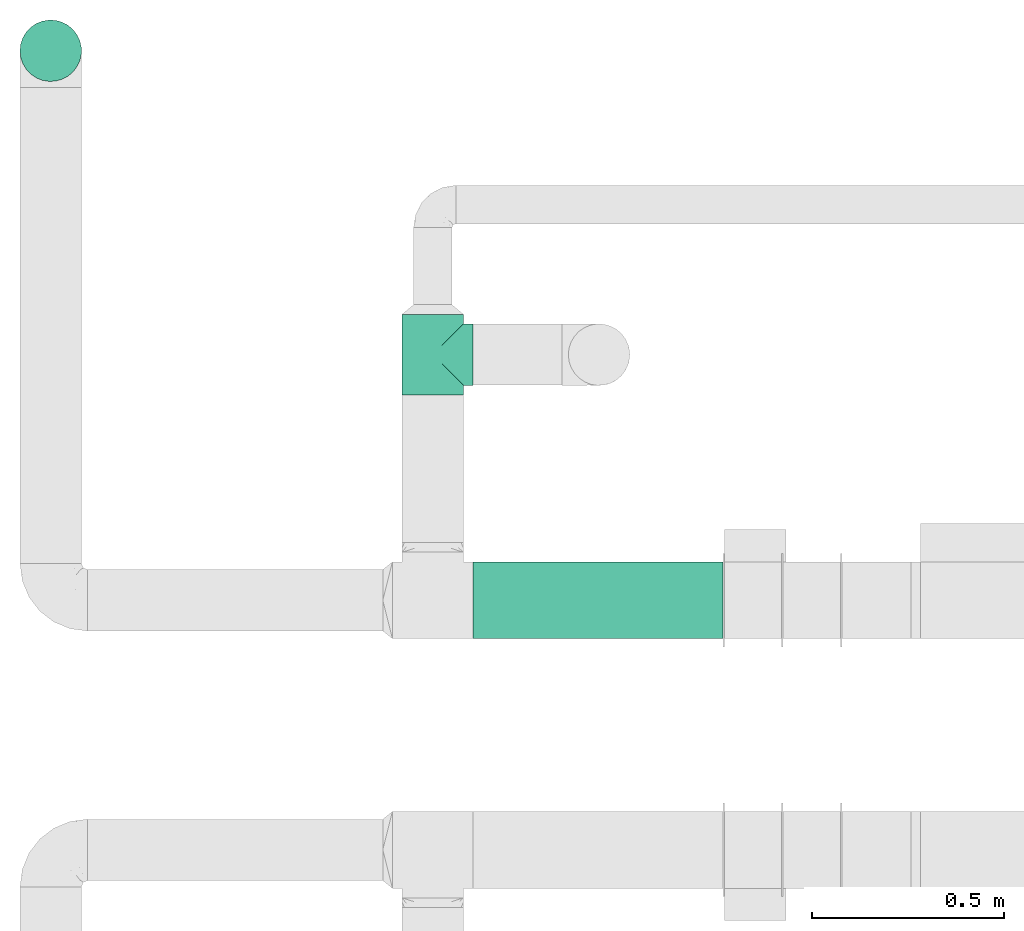
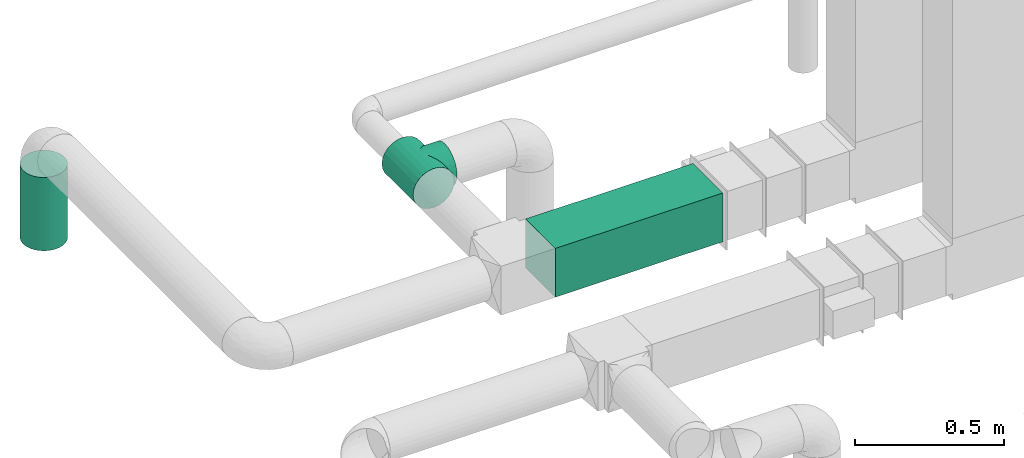
# One storey, part 9 of 12: 2 flow segments, 1 flow fitting.
"""IFC2X3 building model written with IfcOpenShell, lengths in millimetres."""

from ifc_helpers import new_model, entity, si_unit, converted_unit, derived_unit, direction, frame, frame_2d, origin, origin_2d_with_axis, place, context, subcontext, project, spatial, rectangle, circle, extrude, faceted_brep, source, transform, mapped, type_object, type_shapes, element, save


model = new_model("IFC2X3")

# Units and contexts
model_context = context("Model", 3, precision=0.01, world=origin(), true_north=direction((6.12303176911189e-17, 1.0)))
body_context = subcontext(model_context, "Body", "Model", "MODEL_VIEW")
ifc_project = project(units=[si_unit("LENGTHUNIT", "METRE", prefix="MILLI"), si_unit("AREAUNIT", "SQUARE_METRE"), si_unit("VOLUMEUNIT", "CUBIC_METRE"), converted_unit("PLANEANGLEUNIT", "DEGREE", entity("IfcRatioMeasure", 0.0174532925199433), si_unit("PLANEANGLEUNIT", "RADIAN"), dimensions=[0, 0, 0, 0, 0, 0, 0]), si_unit("MASSUNIT", "GRAM", prefix="KILO"), derived_unit("MASSDENSITYUNIT", [(si_unit("MASSUNIT", "GRAM", prefix="KILO"), 1), (si_unit("LENGTHUNIT", "METRE"), -3)]), si_unit("TIMEUNIT", "SECOND"), si_unit("FREQUENCYUNIT", "HERTZ"), si_unit("THERMODYNAMICTEMPERATUREUNIT", "DEGREE_CELSIUS"), derived_unit("THERMALTRANSMITTANCEUNIT", [(si_unit("MASSUNIT", "GRAM", prefix="KILO"), 1), (si_unit("THERMODYNAMICTEMPERATUREUNIT", "KELVIN"), -1), (si_unit("TIMEUNIT", "SECOND"), -3)]), derived_unit("VOLUMETRICFLOWRATEUNIT", [(si_unit("LENGTHUNIT", "METRE"), 3), (si_unit("TIMEUNIT", "SECOND"), -1)]), si_unit("ELECTRICCURRENTUNIT", "AMPERE"), si_unit("ELECTRICVOLTAGEUNIT", "VOLT"), si_unit("POWERUNIT", "WATT"), si_unit("FORCEUNIT", "NEWTON", prefix="KILO"), si_unit("ILLUMINANCEUNIT", "LUX"), si_unit("LUMINOUSFLUXUNIT", "LUMEN"), si_unit("LUMINOUSINTENSITYUNIT", "CANDELA"), derived_unit("USERDEFINED", [(si_unit("MASSUNIT", "GRAM", prefix="KILO"), -1), (si_unit("LENGTHUNIT", "METRE"), -2), (si_unit("TIMEUNIT", "SECOND"), 3), (si_unit("LUMINOUSFLUXUNIT", "LUMEN"), 1)]), derived_unit("LINEARVELOCITYUNIT", [(si_unit("LENGTHUNIT", "METRE"), 1), (si_unit("TIMEUNIT", "SECOND"), -1)]), si_unit("PRESSUREUNIT", "PASCAL"), derived_unit("USERDEFINED", [(si_unit("LENGTHUNIT", "METRE"), -2), (si_unit("MASSUNIT", "GRAM", prefix="KILO"), 1), (si_unit("TIMEUNIT", "SECOND"), -2)])], contexts=[model_context])

# Site, building, storey
site_placement = place(None, origin())
site = spatial("IfcSite", under=ifc_project, at=site_placement, CompositionType="ELEMENT")
building_placement = place(site_placement, origin())
building = spatial("IfcBuilding", under=site, at=building_placement, CompositionType="ELEMENT")
storey_placement = place(building_placement, frame((0.0, 0.0, 4000.0)))
storey = spatial("IfcBuildingStorey", under=building, at=storey_placement, Name="01 Level", CompositionType="ELEMENT", Elevation=4000.0)

# Flow segments
duct_segment_type_1 = type_object("IfcDuctSegmentType", Name="Round Duct:Air", PredefinedType="NOTDEFINED")
flow_segment_1_placement = place(storey_placement, frame((22110.1537099681, -67157.8348573759, 2603.07847999999)))
element("IfcFlowSegment", 1, at=flow_segment_1_placement, inside=storey, type_object=duct_segment_type_1, Name="Round Duct:Air", ObjectType="Round Duct:Air", context=body_context, shape_type="SweptSolid", body=[
    extrude(circle(Radius=79.9999999999999, at=origin_2d_with_axis()), frame((81.595272235915, 81.595272235915, 0.0), z_axis=(0.0, 0.0, 1.0), x_axis=(-1.0, 0.0, 0.0)), (0.0, 0.0, 1.0), 300.921520000008),
])
duct_segment_type_2 = type_object("IfcDuctSegmentType", Name="Rectangular Duct:Air", PredefinedType="NOTDEFINED")
flow_segment_2_placement = place(storey_placement, frame((23290.9900708518, -68606.4439409626, 2900.0)))
element("IfcFlowSegment", 2, at=flow_segment_2_placement, inside=storey, type_object=duct_segment_type_2, Name="Rectangular Duct:Air", ObjectType="Rectangular Duct:Air", context=body_context, shape_type="SweptSolid", body=[
    extrude(rectangle(XDim=650.000000000004, YDim=199.999999999998, at=frame_2d((-2.1600499167107e-12, -4.33431068813661e-12), x_axis=(1.0, 0.0))), frame((325.0, 100.0, 0.0), z_axis=(0.0, 0.0, 1.0), x_axis=(-1.0, 0.0, 0.0)), (0.0, 0.0, 1.0), 200.0),
])

# Flow fitting
duct_fitting_type = type_object("IfcDuctFittingType", Name="Air_Tee 90_Circ", PredefinedType="NOTDEFINED")
shared_shape = source(origin(), body_context, "Body", "Brep", [
    faceted_brep([(-105.0, 0.0, -80.0), (-105.0, -20.705523608202, -77.2740661031254), (-105.0, -40.0, -69.2820323027551), (-105.0, -56.5685424949241, -56.5685424949238), (-105.0, -69.2820323027554, -40.0), (-105.0, -77.2740661031257, -20.7055236082016), (-105.0, -80.0, 0.0), (-105.0, -77.2740661031255, 20.7055236082026), (-105.0, -69.2820323027549, 40.0), (-105.0, -56.5685424949234, 56.5685424949245), (-105.0, -40.0, 69.2820323027556), (-105.0, -20.7055236082011, 77.2740661031257), (-105.0, 0.0, 80.0), (-105.0, 20.7055236082022, 77.2740661031253), (-105.0, 40.0, 69.2820323027547), (-105.0, 48.2842712474623, 62.925287398839), (-105.0, 56.5685424949241, 56.5685424949232), (-105.0, 62.9252873988397, 48.2842712474612), (-105.0, 69.2820323027552, 40.0), (-105.0, 73.2780492029403, 30.3527618041001), (-105.0, 75.2760576530329, 25.5291427061505), (-105.0, 77.2740661031254, 20.7055236082009), (-105.0, 77.955549577344, 15.5291427061506), (-105.0, 78.6370330515626, 10.3527618041003), (-105.0, 79.3185165257812, 5.17638090205002), (-105.0, 80.0, 0.0), (-105.0, 79.3185165257811, -5.17638090205062), (-105.0, 78.6370330515624, -10.3527618041011), (-105.0, 77.9555495773438, -15.5291427061515), (-105.0, 77.2740661031251, -20.7055236082019), (-105.0, 75.2760576530325, -25.5291427061515), (-105.0, 73.2780492029399, -30.352761804101), (-105.0, 69.2820323027547, -40.0), (-105.0, 62.9252873988391, -48.2842712474621), (-105.0, 56.5685424949234, -56.5685424949239), (-105.0, 48.2842712474615, -62.9252873988396), (-105.0, 40.0, -69.2820323027552), (-105.0, 20.7055236082013, -77.2740661031255), (105.0, -40.0, -69.2820323027551), (105.0, -20.7055236082014, -77.2740661031254), (105.0, 0.0, -80.0), (105.0, 20.7055236082019, -77.2740661031255), (105.0, 40.0, -69.2820323027552), (105.0, 48.2842712474622, -62.9252873988395), (105.0, 56.5685424949241, -56.5685424949239), (105.0, 62.9252873988397, -48.2842712474621), (105.0, 69.2820323027554, -40.0), (105.0, 73.2780492029406, -30.352761804101), (105.0, 75.2760576530332, -25.5291427061515), (105.0, 77.2740661031258, -20.7055236082019), (105.0, 77.9555495773445, -15.5291427061515), (105.0, 78.6370330515631, -10.3527618041011), (105.0, 79.3185165257817, -5.17638090205064), (105.0, 80.0, 0.0), (105.0, 79.3185165257818, 5.17638090205008), (105.0, 78.6370330515632, 10.3527618041003), (105.0, 77.9555495773447, 15.5291427061506), (105.0, 77.2740661031261, 20.7055236082009), (105.0, 75.2760576530335, 25.5291427061505), (105.0, 73.278049202941, 30.3527618041001), (105.0, 69.2820323027559, 40.0), (105.0, 62.9252873988403, 48.2842712474612), (105.0, 56.5685424949248, 56.5685424949232), (105.0, 48.284271247463, 62.9252873988389), (105.0, 40.0, 69.2820323027547), (105.0, 20.7055236082029, 77.2740661031253), (105.0, 0.0, 80.0), (105.0, -20.7055236082004, 77.2740661031257), (105.0, -40.0, 69.2820323027556), (105.0, -56.5685424949228, 56.5685424949245), (105.0, -69.2820323027542, 40.0), (105.0, -77.2740661031248, 20.7055236082026), (105.0, -80.0, 0.0), (105.0, -77.2740661031251, -20.7055236082016), (105.0, -69.2820323027547, -40.0), (105.0, -56.5685424949235, -56.5685424949238), (78.227899039511, 78.2278990395113, 16.7450234954769), (-78.227899039511, 78.2278990395108, 16.7450234954769), (79.1139495197555, 79.1139495197558, 8.37251174773832), (76.9834675239615, 76.9834675239618, 20.5993372484815), (75.7390360084121, 75.7390360084124, 24.4536510014862), (73.2501729773131, 73.2501729773134, 32.1622785074954), (61.2529055661489, 61.2529055661492, 50.9613067090927), (56.6842556369154, 56.6842556369157, 56.452592171563), (46.3970120620784, 46.3970120620786, 65.1714452172986), (-73.2501729773132, 73.250172977313, 32.1622785074954), (65.8215554953824, 65.8215554953827, 45.4700212466224), (-46.3970120620785, 46.3970120620784, 65.1714452172985), (-69.5358642363478, 69.5358642363476, 38.8161498770589), (-65.8215554953824, 65.8215554953822, 45.4700212466225), (69.5358642363477, 69.5358642363481, 38.8161498770589), (-75.7390360084121, 75.7390360084119, 24.4536510014861), (-76.9834675239616, 76.9834675239614, 20.5993372484815), (-78.6709242796333, 78.6709242796331, 12.5587676216076), (-79.1139495197555, 79.1139495197553, 8.37251174773832), (-79.5569747598778, 79.5569747598776, 4.18625587386907), (-80.0, 80.0, 0.0), (80.0, 80.0, 0.0), (79.5569747598777, 79.5569747598781, 4.18625587386903), (78.6709242796332, 78.6709242796336, 12.5587676216076), (-56.6842556369155, 56.6842556369154, 56.452592171563), (-61.252905566149, 61.2529055661488, 50.9613067090927), (-35.3477594379945, 35.3477594379945, 71.7672341860383), (35.3477594379944, 35.3477594379946, 71.7672341860384), (11.9716475671883, 11.9716475671884, 79.0991760673083), (23.8067106814643, 23.8067106814644, 76.3756540170299), (0.0, 0.0, 80.0), (-11.9716475671884, 11.9716475671884, 79.0991760673083), (-23.8067106814644, 23.8067106814643, 76.3756540170299), (-79.1139495197555, 79.1139495197553, -8.3725117477387), (-78.6709242796332, 78.670924279633, -12.5587676216079), (-79.5569747598777, 79.5569747598776, -4.18625587386946), (79.5569747598777, 79.5569747598781, -4.18625587386948), (75.7390360084119, 75.7390360084122, -24.4536510014866), (0.0, 0.0, -80.0), (11.971647567188, 11.9716475671882, -79.0991760673083), (-75.739036008412, 75.7390360084118, -24.4536510014865), (-11.9716475671881, 11.9716475671881, -79.0991760673083), (23.806710681464, 23.8067106814643, -76.3756540170299), (69.5358642363476, 69.5358642363478, -38.8161498770593), (73.250172977313, 73.2501729773133, -32.1622785074958), (65.8215554953821, 65.8215554953824, -45.4700212466228), (78.6709242796332, 78.6709242796335, -12.558767621608), (79.1139495197555, 79.1139495197558, -8.37251174773877), (61.2529055661487, 61.252905566149, -50.961306709093), (-69.5358642363476, 69.5358642363474, -38.8161498770592), (-65.8215554953822, 65.8215554953821, -45.4700212466227), (-73.250172977313, 73.2501729773128, -32.1622785074957), (76.9834675239614, 76.9834675239618, -20.5993372484819), (78.2278990395109, 78.2278990395112, -16.7450234954773), (-35.3477594379943, 35.3477594379942, -71.7672341860385), (-23.8067106814641, 23.8067106814641, -76.37565401703), (35.3477594379942, 35.3477594379944, -71.7672341860385), (56.6842556369152, 56.6842556369155, -56.4525921715632), (-46.3970120620782, 46.3970120620781, -65.1714452172987), (-56.6842556369153, 56.6842556369152, -56.4525921715632), (46.3970120620782, 46.3970120620784, -65.1714452172987), (-76.9834675239615, 76.9834675239613, -20.5993372484819), (-78.2278990395109, 78.2278990395108, -16.7450234954772), (-61.2529055661488, 61.2529055661486, -50.9613067090929), (40.0, 105.0, -69.2820323027551), (20.7055236082017, 105.0, -77.2740661031254), (0.0, 105.0, -80.0), (-20.7055236082016, 105.0, -77.2740661031255), (-40.0, 105.0, -69.2820323027552), (-56.5685424949237, 105.0, -56.5685424949239), (-69.282032302755, 105.0, -40.0), (-73.2780492029402, 105.0, -30.352761804101), (-77.2740661031254, 105.0, -20.7055236082019), (-78.6370330515627, 105.0, -10.352761804101), (-80.0, 105.0, 0.0), (-78.6370330515629, 105.0, 10.3527618041003), (-77.2740661031257, 105.0, 20.7055236082009), (-73.2780492029406, 105.0, 30.3527618041001), (-69.2820323027555, 105.0, 40.0), (-56.5685424949244, 105.0, 56.5685424949232), (-40.0, 105.0, 69.2820323027547), (-20.7055236082025, 105.0, 77.2740661031253), (0.0, 105.0, 80.0), (20.7055236082008, 105.0, 77.2740661031257), (40.0, 105.0, 69.2820323027556), (56.5685424949231, 105.0, 56.5685424949245), (69.2820323027546, 105.0, 40.0), (73.2780492029399, 105.0, 30.3527618041017), (77.2740661031252, 105.0, 20.7055236082026), (78.6370330515626, 105.0, 10.3527618041018), (80.0, 105.0, 0.0), (78.6370330515627, 105.0, -10.3527618041008), (77.2740661031254, 105.0, -20.7055236082016), (73.2780492029403, 105.0, -30.3527618041008), (69.2820323027551, 105.0, -40.0), (56.5685424949238, 105.0, -56.5685424949238)], [[[0, 1, 2, 3, 4, 5, 6, 7, 8, 9, 10, 11, 12, 13, 14, 15, 16, 17, 18, 19, 20, 21, 22, 23, 24, 25, 26, 27, 28, 29, 30, 31, 32, 33, 34, 35, 36, 37]], [[38, 39, 40, 41, 42, 43, 44, 45, 46, 47, 48, 49, 50, 51, 52, 53, 54, 55, 56, 57, 58, 59, 60, 61, 62, 63, 64, 65, 66, 67, 68, 69, 70, 71, 72, 73, 74, 75]], [[76, 57, 56]], [[22, 21, 77]], [[78, 55, 54]], [[57, 76, 79, 80]], [[81, 60, 59]], [[82, 83, 62]], [[64, 63, 84]], [[19, 18, 85]], [[82, 61, 86]], [[63, 62, 83]], [[15, 14, 87]], [[88, 85, 18, 89]], [[81, 90, 86, 60]], [[91, 92, 77, 21]], [[91, 19, 85]], [[20, 19, 91, 21]], [[22, 77, 93]], [[94, 95, 24]], [[96, 25, 95]], [[97, 98, 53]], [[58, 57, 80, 59]], [[76, 56, 99]], [[100, 101, 16]], [[100, 15, 87]], [[101, 17, 16]], [[18, 17, 89]], [[16, 15, 100]], [[78, 99, 55]], [[61, 82, 62]], [[102, 87, 14]], [[93, 23, 22]], [[101, 89, 17]], [[103, 64, 84]], [[104, 66, 65]], [[54, 53, 98]], [[65, 103, 105]], [[65, 105, 104]], [[61, 60, 86]], [[106, 66, 104]], [[12, 106, 107]], [[64, 103, 65]], [[70, 69, 9, 8]], [[71, 70, 8, 7]], [[68, 67, 11, 10]], [[69, 68, 10, 9]], [[66, 106, 12, 11, 67]], [[72, 71, 7, 6]], [[81, 59, 80]], [[13, 107, 108]], [[102, 13, 108]], [[12, 107, 13]], [[55, 99, 56]], [[14, 13, 102]], [[84, 63, 83]], [[24, 95, 25]], [[24, 23, 94]], [[98, 78, 54]], [[93, 94, 23]], [[109, 110, 27]], [[96, 111, 25]], [[97, 53, 112]], [[48, 47, 113, 49]], [[74, 4, 3, 75]], [[74, 73, 5, 4]], [[38, 75, 3, 2]], [[73, 72, 6, 5]], [[40, 39, 1, 0, 114]], [[111, 109, 26]], [[41, 40, 115]], [[30, 29, 116, 31]], [[40, 114, 115]], [[117, 114, 0]], [[41, 115, 118]], [[119, 120, 46, 121]], [[122, 51, 50]], [[1, 39, 38, 2]], [[122, 123, 51]], [[124, 121, 45]], [[52, 51, 123]], [[125, 126, 32, 127]], [[113, 128, 129, 49]], [[37, 130, 131]], [[37, 131, 117]], [[37, 117, 0]], [[37, 36, 130]], [[132, 41, 118]], [[43, 133, 44]], [[134, 35, 135]], [[133, 43, 136]], [[124, 45, 44]], [[127, 31, 116]], [[121, 46, 45]], [[132, 136, 42]], [[52, 123, 112]], [[50, 49, 129]], [[113, 47, 120]], [[129, 122, 50]], [[137, 116, 29, 138]], [[52, 112, 53]], [[33, 139, 34]], [[133, 124, 44]], [[43, 42, 136]], [[35, 34, 135]], [[130, 36, 134]], [[36, 35, 134]], [[33, 126, 139]], [[135, 34, 139]], [[33, 32, 126]], [[47, 46, 120]], [[26, 25, 111]], [[109, 27, 26]], [[32, 31, 127]], [[28, 138, 29]], [[27, 110, 28]], [[138, 28, 110]], [[41, 132, 42]], [[140, 141, 142, 143, 144, 145, 146, 147, 148, 149, 150, 151, 152, 153, 154, 155, 156, 157, 158, 159, 160, 161, 162, 163, 164, 165, 166, 167, 168, 169, 170, 171]], [[77, 152, 151]], [[165, 164, 76]], [[94, 151, 150]], [[152, 77, 92, 91, 85]], [[87, 156, 155]], [[155, 154, 89]], [[154, 153, 152, 85]], [[157, 156, 102]], [[165, 78, 166]], [[154, 85, 88, 89]], [[155, 100, 87]], [[155, 89, 101, 100]], [[157, 102, 108]], [[107, 106, 158]], [[107, 157, 108]], [[102, 156, 87]], [[158, 157, 107]], [[159, 103, 160]], [[158, 104, 159]], [[161, 160, 84]], [[166, 78, 98, 97]], [[86, 162, 161]], [[163, 162, 81, 164]], [[165, 76, 99, 78]], [[160, 103, 84]], [[159, 104, 105]], [[159, 105, 103]], [[164, 81, 80, 79, 76]], [[150, 96, 95, 94]], [[161, 83, 82, 86]], [[151, 94, 93, 77]], [[162, 86, 90, 81]], [[83, 161, 84]], [[106, 104, 158]], [[129, 168, 167]], [[169, 168, 120, 170]], [[123, 167, 166]], [[168, 129, 128, 113, 120]], [[147, 146, 127, 148]], [[149, 109, 150]], [[171, 170, 121]], [[149, 148, 138]], [[136, 140, 171]], [[141, 140, 132]], [[170, 120, 119, 121]], [[171, 133, 136]], [[171, 121, 124, 133]], [[141, 132, 118]], [[115, 114, 142]], [[115, 141, 118]], [[132, 140, 136]], [[167, 123, 122, 129]], [[142, 141, 115]], [[143, 130, 144]], [[142, 117, 143]], [[145, 144, 134]], [[150, 109, 111, 96]], [[126, 146, 145]], [[149, 138, 110, 109]], [[144, 130, 134]], [[143, 117, 131]], [[143, 131, 130]], [[166, 97, 112, 123]], [[148, 127, 116, 137, 138]], [[145, 135, 139, 126]], [[146, 126, 125, 127]], [[135, 145, 134]], [[114, 117, 142]]]),
])
type_shapes(duct_fitting_type, [shared_shape])
flow_fitting_placement = place(storey_placement, frame((23185.9900708518, -67867.2449387878, 3000.0), z_axis=(0.0, 0.0, 1.0), x_axis=(0.0, -1.0, 0.0)))
element("IfcFlowFitting", 3, at=flow_fitting_placement, inside=storey, type_object=duct_fitting_type, Name="tee_90_001:Air_Tee 90_Circ", ObjectType="tee_90_001:Air_Tee 90_Circ", context=body_context, shape_type="MappedRepresentation", body=[
    mapped(shared_shape, transform((0.0, 0.0, 0.0), scale=1.0)),
])

save(model, "model.ifc")
